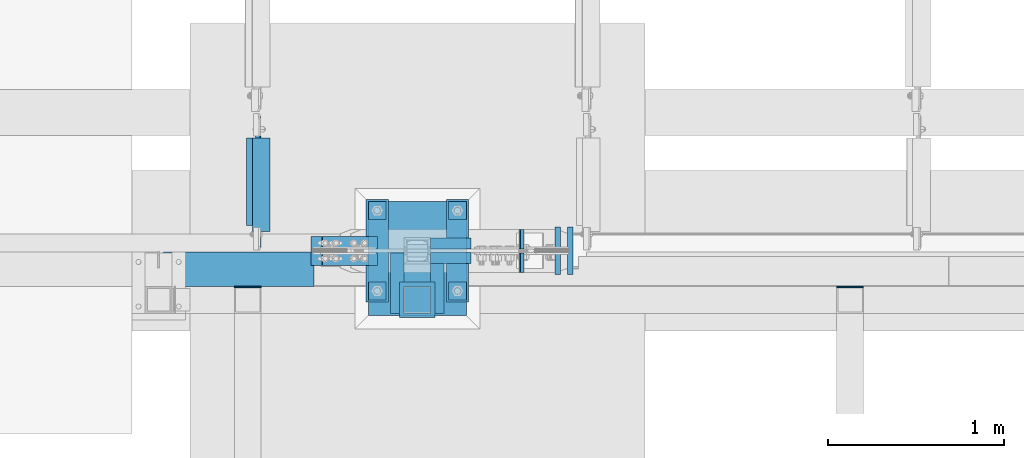
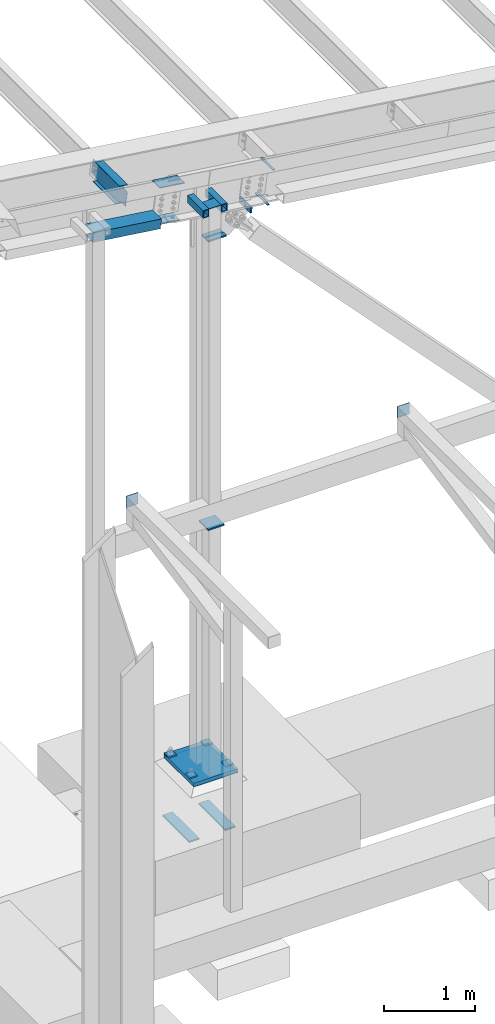
# One storey, part 848 of 1179: 22 beams, 2 members, 11 elements without a shape of their own.
"""IFC2X3 building model written with IfcOpenShell, lengths in millimetres."""

from ifc_helpers import new_model, si_unit, frame, origin_with_axes, place, context, subcontext, project, spatial, faceted_brep, material, type_object, element, aggregate, save


model = new_model("IFC2X3")

# Units and contexts
model_context = context("Model", 3, precision=1e-05, world=origin_with_axes())
body_context = subcontext(model_context, "Body", "Model", "MODEL_VIEW")
ifc_project = project(units=[si_unit("LENGTHUNIT", "METRE", prefix="MILLI"), si_unit("AREAUNIT", "SQUARE_METRE"), si_unit("VOLUMEUNIT", "CUBIC_METRE"), si_unit("MASSUNIT", "GRAM", prefix="KILO"), si_unit("TIMEUNIT", "SECOND"), si_unit("PLANEANGLEUNIT", "RADIAN"), si_unit("SOLIDANGLEUNIT", "STERADIAN"), si_unit("THERMODYNAMICTEMPERATUREUNIT", "DEGREE_CELSIUS"), si_unit("LUMINOUSINTENSITYUNIT", "LUMEN")], contexts=[model_context])

# Site, building, storey
site_placement = place(None, origin_with_axes())
site = spatial("IfcSite", under=ifc_project, at=site_placement, CompositionType="ELEMENT")
building_placement = place(site_placement, origin_with_axes())
building = spatial("IfcBuilding", under=site, at=building_placement, Name="Undefined", CompositionType="ELEMENT")
storey_placement = place(building_placement, origin_with_axes())
storey = spatial("IfcBuildingStorey", under=building, at=storey_placement, Name="Undefined", CompositionType="ELEMENT", Elevation=0.0)

# Assembly, beam
assembly_1_placement = place(storey_placement, origin_with_axes())
assembly_1 = element("IfcElementAssembly", 1, at=assembly_1_placement, inside=storey, Name="BEAM", AssemblyPlace="NOTDEFINED", PredefinedType="RIGID_FRAME")
ifc_material_1 = material(Name="STEEL/A992")
beam_type_1 = type_object("IfcBeamType", Name="W10X12", PredefinedType="NOTDEFINED")
beam_1_placement = place(assembly_1_placement, frame((26856.4181490507, 4648.2, 7565.95174486026), z_axis=(0.133813223953133, 0.0, 0.991006569652931), x_axis=(0.0, 1.0, 0.0)))
beam_1 = element("IfcBeam", 2, at=beam_1_placement, type_object=beam_type_1, material=ifc_material_1, Name="BEAM", ObjectType="W10X12", context=body_context, shape_type="Brep", body=[
    faceted_brep([(641.349999999998, -2.38124999986758, -120.650000000041), (641.349999999998, -50.7999999998792, -120.650000000054), (641.349999999998, -50.7999999998719, -125.412500000057), (641.349999999998, 50.8000000001484, -125.412500000028), (641.349999999998, 50.8000000001412, -120.650000000027), (641.349999999998, 2.38125000012951, -120.650000000038), (641.349999999998, 2.38125000012224, -106.362499801333), (641.349999999998, -2.38124999988213, -106.362499801329), (642.316729922585, 2.38125000011496, -101.502420283283), (642.316729922585, -2.38124999988213, -101.502420283279), (645.069743823064, 2.38125000011496, -97.3822438151255), (645.069743823064, -2.38124999988941, -97.3822438151219), (649.189920291217, 2.38125000010768, -94.6292299146444), (649.189920291217, -2.38124999989668, -94.6292299146407), (654.049999809263, 2.38125000010768, -93.6624999920532), (654.049999809263, -2.38124999989668, -93.6624999920496), (768.349999999998, -2.38124999988941, -93.6624999919513), (768.349999999998, 2.38125000010768, -93.6624999919441), (109.537500000001, 2.38124999985303, 120.650000000041), (109.537500000001, 50.7999999998647, 120.650000000056), (642.937499999997, 50.7999999998647, 120.650000000056), (642.937499999997, 2.38124999985303, 120.650000000041), (144.462500000001, -2.38124999988213, -106.362499807816), (144.462500000001, 2.38125000011496, -106.362499807819), (144.462500000001, 2.38125000012951, -120.650000000038), (144.462500000001, 50.8000000001412, -120.650000000027), (144.462500000001, 50.8000000001484, -125.412500000028), (144.462500000001, -50.7999999998719, -125.412500000057), (144.462500000001, -50.7999999998792, -120.650000000054), (144.462500000001, -2.38124999986758, -120.650000000041), (143.495770077414, -2.38124999988213, -101.502420289766), (143.495770077414, 2.38125000011496, -101.502420289768), (140.742756176935, -2.38124999988941, -97.3822438216066), (140.742756176935, 2.38125000011496, -97.3822438216102), (136.622579708782, -2.38124999989668, -94.6292299211254), (136.622579708782, 2.38125000010768, -94.6292299211291), (131.762500190736, -2.38124999988941, -93.6624999985379), (131.762500190736, 2.38125000010768, -93.6624999985397), (17.4624999999996, -2.38124999988941, -93.662499998647), (17.4624999999996, 2.38125000010768, -93.6624999986416), (17.4624999999996, -2.38125000011496, 93.6625000015429), (17.4624999999996, 2.38124999988941, 93.6625000015483), (96.8375001907361, -2.38125000011496, 93.662500001652), (96.8375001907361, 2.38124999988941, 93.6625000016502), (101.697579708782, -2.38125000011496, 94.6292299242414), (101.697579708782, 2.38124999987485, 94.6292299242377), (105.817756176935, -2.38125000011496, 97.3822438247225), (105.817756176935, 2.38124999988213, 97.3822438247189), (108.570770077414, -2.38125000012224, 101.50242029288), (108.570770077414, 2.38124999987485, 101.502420292876), (109.537500000001, -2.38125000012951, 106.36249981093), (109.537500000001, 2.38124999986758, 106.362499810928), (109.537500000001, -50.800000000163, 125.412500000028), (109.537500000001, 50.7999999998574, 125.412500000059), (109.537500000001, -2.38125000014406, 120.650000000041), (109.537500000001, -50.8000000001557, 120.650000000027), (642.937499999997, -2.38125000014406, 120.650000000041), (642.937499999997, -50.8000000001557, 120.650000000027), (642.937499999997, -50.800000000163, 125.412500000028), (642.937499999997, 50.7999999998574, 125.412500000059), (642.937499999997, -2.38125000012224, 100.012499817411), (642.937499999997, 2.38124999987485, 100.012499817409), (643.904229922585, -2.38125000012224, 95.1524202993623), (643.904229922585, 2.38124999988213, 95.1524202993587), (646.657243823063, -2.38125000011496, 91.0322438312032), (646.657243823063, 2.38124999988941, 91.0322438311996), (650.777420291217, -2.38125000010768, 88.2792299307239), (650.777420291217, 2.38124999988941, 88.2792299307202), (655.637499809262, -2.38125000010768, 87.3125000081345), (655.637499809262, 2.38124999988941, 87.3125000081309), (768.349999999998, -2.38125000010768, 87.3125000082346), (768.349999999998, 2.38124999988941, 87.31250000824)], [[[0, 1, 2, 3, 4, 5, 6, 7]], [[7, 6, 8, 9]], [[9, 8, 10, 11]], [[11, 10, 12, 13]], [[13, 12, 14, 15]], [[16, 15, 14, 17]], [[18, 19, 20, 21]], [[22, 23, 24, 25, 26, 27, 28, 29]], [[30, 31, 23, 22]], [[32, 33, 31, 30]], [[34, 35, 33, 32]], [[36, 37, 35, 34]], [[38, 39, 37, 36]], [[40, 41, 39, 38]], [[42, 43, 41, 40]], [[44, 45, 43, 42]], [[46, 47, 45, 44]], [[48, 49, 47, 46]], [[50, 51, 49, 48]], [[52, 53, 19, 18, 51, 50, 54, 55]], [[55, 54, 56, 57]], [[52, 55, 57, 58]], [[53, 52, 58, 59]], [[19, 53, 59, 20]], [[58, 57, 56, 60, 61, 21, 20, 59]], [[62, 63, 61, 60]], [[64, 65, 63, 62]], [[66, 67, 65, 64]], [[68, 69, 67, 66]], [[70, 71, 69, 68]], [[71, 70, 16, 17]], [[12, 10, 8, 6, 5, 24, 23, 31, 33, 35, 37, 39, 41, 43, 45, 47, 49, 51, 18, 21, 61, 63, 65, 67, 69, 71, 17, 14]], [[25, 24, 5, 4]], [[26, 25, 4, 3]], [[27, 26, 3, 2]], [[28, 27, 2, 1]], [[29, 28, 1, 0]], [[70, 68, 66, 64, 62, 60, 56, 54, 50, 48, 46, 44, 42, 40, 38, 36, 34, 32, 30, 22, 29, 0, 7, 9, 11, 13, 15, 16]]]),
])
aggregate(assembly_1, [beam_1])

assembly_2_placement = place(storey_placement, origin_with_axes())
assembly_2 = element("IfcElementAssembly", 3, at=assembly_2_placement, inside=storey, Name="COLUMN", AssemblyPlace="NOTDEFINED", PredefinedType="RIGID_FRAME")
ifc_material_2 = material(Name="STEEL/A36")
beam_type_2 = type_object("IfcBeamType", PredefinedType="NOTDEFINED")
beam_2_placement = place(assembly_2_placement, frame((27762.2, 4292.6, 7370.69880466022), z_axis=(1.0, 0.0, 0.0), x_axis=(0.0, 1.0, 0.0)))
beam_2 = element("IfcBeam", 4, at=beam_2_placement, type_object=beam_type_2, material=ifc_material_2, Name="PLATE", context=body_context, shape_type="Brep", body=[
    faceted_brep([(-1.47792889038101e-12, 3.17500000000018, -76.1999999999953), (1.36424205265939e-12, 3.17500000000018, 76.1999999999953), (152.399999999989, 3.17500000000018, 76.200000000028), (152.399999999986, 3.17500000000018, -76.1999999999625), (1.36424205265939e-12, -3.17500000000018, 76.1999999999953), (152.399999999989, -3.17500000000018, 76.200000000028), (-1.47792889038101e-12, -3.17500000000018, -76.1999999999953), (152.399999999986, -3.17500000000018, -76.1999999999625)], [[[0, 1, 2, 3]], [[1, 4, 5, 2]], [[4, 6, 7, 5]], [[6, 0, 3, 7]], [[5, 7, 3, 2]], [[6, 4, 1, 0]]]),
])

assembly_3_placement = place(storey_placement, origin_with_axes())
assembly_3 = element("IfcElementAssembly", 5, at=assembly_3_placement, inside=storey, Name="BEAM", AssemblyPlace="NOTDEFINED", PredefinedType="RIGID_FRAME")
beam_3_placement = place(assembly_3_placement, frame((30302.2, 4441.825, 3702.05), z_axis=(0.0, 0.0, -1.0), x_axis=(-1.0, 0.0, 0.0)))
beam_3 = element("IfcBeam", 6, at=beam_3_placement, type_object=beam_type_2, material=ifc_material_2, Name="PLATE", context=body_context, shape_type="Brep", body=[
    faceted_brep([(-1.47792889038101e-12, 3.17500000000018, -76.1999999999953), (1.36424205265939e-12, 3.17500000000018, 76.1999999999953), (152.399999999989, 3.17500000000018, 76.200000000028), (152.399999999986, 3.17500000000018, -76.1999999999625), (1.36424205265939e-12, -3.17500000000018, 76.1999999999953), (152.399999999989, -3.17500000000018, 76.200000000028), (-1.47792889038101e-12, -3.17500000000018, -76.1999999999953), (152.399999999986, -3.17500000000018, -76.1999999999625)], [[[0, 1, 2, 3]], [[1, 4, 5, 2]], [[4, 6, 7, 5]], [[6, 0, 3, 7]], [[5, 7, 3, 2]], [[6, 4, 1, 0]]]),
])
aggregate(assembly_3, [beam_3])

assembly_4_placement = place(storey_placement, origin_with_axes())
assembly_4 = element("IfcElementAssembly", 7, at=assembly_4_placement, inside=storey, Name="BEAM", AssemblyPlace="NOTDEFINED", PredefinedType="RIGID_FRAME")
beam_4_placement = place(assembly_4_placement, frame((26873.2, 4441.825, 3702.05), z_axis=(0.0, 0.0, -1.0), x_axis=(-1.0, 0.0, 0.0)))
beam_4 = element("IfcBeam", 8, at=beam_4_placement, type_object=beam_type_2, material=ifc_material_2, Name="PLATE", context=body_context, shape_type="Brep", body=[
    faceted_brep([(-1.47792889038101e-12, 3.17500000000018, -76.1999999999953), (1.36424205265939e-12, 3.17500000000018, 76.1999999999953), (152.399999999989, 3.17500000000018, 76.200000000028), (152.399999999986, 3.17500000000018, -76.1999999999625), (1.36424205265939e-12, -3.17500000000018, 76.1999999999953), (152.399999999989, -3.17500000000018, 76.200000000028), (-1.47792889038101e-12, -3.17500000000018, -76.1999999999953), (152.399999999986, -3.17500000000018, -76.1999999999625)], [[[0, 1, 2, 3]], [[1, 4, 5, 2]], [[4, 6, 7, 5]], [[6, 0, 3, 7]], [[5, 7, 3, 2]], [[6, 4, 1, 0]]]),
])
aggregate(assembly_4, [beam_4])

# Assembly, beams
assembly_5_placement = place(storey_placement, origin_with_axes())
assembly_5 = element("IfcElementAssembly", 9, at=assembly_5_placement, inside=storey, Name="BEAM", AssemblyPlace="NOTDEFINED", PredefinedType="RIGID_FRAME")
ifc_material_3 = material(Name="STEEL/A572-GR.50")
beam_type_3 = type_object("IfcBeamType", PredefinedType="NOTDEFINED")
beam_5_placement = place(assembly_5_placement, frame((28546.3739735034, 4648.2000010376, 6988.54544430494), z_axis=(0.0, -1.0, 0.0), x_axis=(0.99100656965293, 0.0, -0.133813223953134)))
beam_5 = element("IfcBeam", 10, at=beam_5_placement, type_object=beam_type_3, material=ifc_material_3, Name="PLATE", context=body_context, shape_type="Brep", body=[
    faceted_brep([(7.27595761418343e-12, 4.76250000000437, -134.9375), (7.27595761418343e-12, 4.76250000000437, 134.9375), (31.7500000000182, 4.76249999999527, 134.9375), (31.7500000000182, 4.76249999999527, -134.9375), (-3.63797880709171e-12, -4.76249999999891, 134.9375), (31.7500000000073, -4.762500000008, 134.9375), (-3.63797880709171e-12, -4.76249999999891, -134.9375), (31.7500000000073, -4.762500000008, -134.9375)], [[[0, 1, 2, 3]], [[1, 4, 5, 2]], [[4, 6, 7, 5]], [[6, 0, 3, 7]], [[5, 7, 3, 2]], [[6, 4, 1, 0]]]),
])
beam_6_placement = place(assembly_5_placement, frame((28617.2378463457, 4648.2000010376, 7430.31393517149), z_axis=(0.0, -1.0, 0.0), x_axis=(0.99100656965293, 0.0, -0.133813223953134)))
beam_6 = element("IfcBeam", 11, at=beam_6_placement, type_object=beam_type_3, material=ifc_material_3, Name="PLATE", context=body_context, shape_type="Brep", body=[
    faceted_brep([(7.27595761418343e-12, 4.76250000000437, -134.9375), (7.27595761418343e-12, 4.76250000000437, 134.9375), (31.7500000000182, 4.76249999999527, 134.9375), (31.7500000000182, 4.76249999999527, -134.9375), (-3.63797880709171e-12, -4.76249999999891, 134.9375), (31.7500000000073, -4.762500000008, 134.9375), (-3.63797880709171e-12, -4.76249999999891, -134.9375), (31.7500000000073, -4.762500000008, -134.9375)], [[[0, 1, 2, 3]], [[1, 4, 5, 2]], [[4, 6, 7, 5]], [[6, 0, 3, 7]], [[5, 7, 3, 2]], [[6, 4, 1, 0]]]),
])
aggregate(assembly_5, [beam_5, beam_6])

assembly_6_placement = place(storey_placement, origin_with_axes())
assembly_6 = element("IfcElementAssembly", 12, at=assembly_6_placement, inside=storey, Name="TEMPLATE", AssemblyPlace="NOTDEFINED", PredefinedType="RIGID_FRAME")
beam_type_4 = type_object("IfcBeamType", PredefinedType="NOTDEFINED")
beam_7_placement = place(assembly_6_placement, frame((27990.8000061035, 4356.1, -1057.275), z_axis=(-1.0, 0.0, 0.0), x_axis=(0.0, 1.0, 0.0)))
beam_7 = element("IfcBeam", 13, at=beam_7_placement, type_object=beam_type_4, material=ifc_material_2, Name="SQ WASHER", context=body_context, shape_type="Brep", body=[
    faceted_brep([(0.0, 9.52500000000146, -63.5), (0.0, 9.52500000000146, 63.5), (584.199999999997, 9.52500000000009, 63.5), (584.199999999997, 9.52500000000009, -63.5), (0.0, -9.52500000000146, 63.5), (584.199999999997, -9.52500000000009, 63.5), (0.0, -9.52500000000146, -63.5), (584.199999999997, -9.52500000000009, -63.5)], [[[0, 1, 2, 3]], [[1, 4, 5, 2]], [[4, 6, 7, 5]], [[6, 0, 3, 7]], [[5, 7, 3, 2]], [[6, 4, 1, 0]]]),
])
beam_8_placement = place(assembly_6_placement, frame((27533.5999938965, 4940.3, -1057.275), z_axis=(1.0, 0.0, 0.0), x_axis=(0.0, -1.0, 0.0)))
beam_8 = element("IfcBeam", 14, at=beam_8_placement, type_object=beam_type_4, material=ifc_material_2, Name="SQ WASHER", context=body_context, shape_type="Brep", body=[
    faceted_brep([(0.0, 9.52500000000146, -63.5), (0.0, 9.52500000000146, 63.5), (584.199999999997, 9.52500000000009, 63.5), (584.199999999997, 9.52500000000009, -63.5), (0.0, -9.52500000000146, 63.5), (584.199999999997, -9.52500000000009, 63.5), (0.0, -9.52500000000146, -63.5), (584.199999999997, -9.52500000000009, -63.5)], [[[0, 1, 2, 3]], [[1, 4, 5, 2]], [[4, 6, 7, 5]], [[6, 0, 3, 7]], [[5, 7, 3, 2]], [[6, 4, 1, 0]]]),
])

# Assembly, beam
assembly_7_placement = place(storey_placement, origin_with_axes())
assembly_7 = element("IfcElementAssembly", 15, at=assembly_7_placement, inside=storey, Name="COLUMN", AssemblyPlace="NOTDEFINED", PredefinedType="RIGID_FRAME")
beam_type_5 = type_object("IfcBeamType", PredefinedType="NOTDEFINED")
beam_9_placement = place(assembly_7_placement, frame((27762.2, 4267.2, 3101.975), z_axis=(1.0, 0.0, 0.0), x_axis=(0.0, 1.0, 0.0)))
beam_9 = element("IfcBeam", 16, at=beam_9_placement, type_object=beam_type_5, material=ifc_material_2, Name="PLATE", context=body_context, shape_type="Brep", body=[
    faceted_brep([(0.0, 9.52500000000009, -101.599999999999), (0.0, 9.52500000000009, 101.599999999999), (203.199999999999, 9.52500000000009, 101.599999999999), (203.199999999999, 9.52500000000009, -101.599999999999), (0.0, -9.52500000000009, 101.599999999999), (203.199999999999, -9.52500000000009, 101.599999999999), (0.0, -9.52500000000009, -101.599999999999), (203.199999999999, -9.52500000000009, -101.599999999999)], [[[0, 1, 2, 3]], [[1, 4, 5, 2]], [[4, 6, 7, 5]], [[6, 0, 3, 7]], [[5, 7, 3, 2]], [[6, 4, 1, 0]]]),
])
aggregate(assembly_7, [beam_9])

# Beam
ifc_material_4 = material()
beam_type_6 = type_object("IfcBeamType", Name="HSS4X3X5/16", PredefinedType="NOTDEFINED")
beam_10_placement = place(assembly_2_placement, frame((27876.5, 4292.6, 7323.07380466022), z_axis=(0.0, 0.0, 1.0), x_axis=(0.0, 1.0, 0.0)))
beam_10 = element("IfcBeam", 17, at=beam_10_placement, type_object=beam_type_6, material=ifc_material_4, Name="BEAM", ObjectType="HSS4X3X5/16", context=body_context, shape_type="Brep", body=[
    faceted_brep([(0.0, 30.1624999999985, -42.8625000000002), (0.0, -30.1624999999985, -42.8625000000002), (344.487500000005, -30.1624999999985, -42.8625000000002), (344.487500000005, 30.1624999999985, -42.8625000000002), (0.0, -30.1624999999985, 42.8625000000002), (344.487500000005, -30.1624999999985, 42.8625000000002), (0.0, 30.1624999999985, 42.8625000000002), (344.487500000005, 30.1624999999985, 42.8625000000002), (0.0, 38.0999999999985, -50.8000000000002), (1.45519152283669e-11, 38.1000000000004, 50.8000000000002), (344.487500000005, 38.0999999999985, 50.8000000000002), (344.487500000005, 38.0999999999985, -50.8000000000002), (0.0, -38.0999999999985, 50.8000000000002), (344.487500000005, -38.0999999999985, 50.8000000000002), (0.0, -38.0999999999985, -50.8000000000002), (344.487500000005, -38.0999999999985, -50.8000000000002)], [[[0, 1, 2, 3]], [[1, 4, 5, 2]], [[4, 6, 7, 5]], [[6, 0, 3, 7]], [[8, 9, 10, 11]], [[9, 12, 13, 10]], [[12, 14, 15, 13]], [[14, 8, 11, 15]], [[13, 15, 11, 10], [5, 7, 3, 2]], [[14, 12, 9, 8], [6, 4, 1, 0]]]),
])

beam_11_placement = place(assembly_2_placement, frame((27647.9, 4292.6, 7323.07380466022), z_axis=(0.0, 0.0, 1.0), x_axis=(0.0, 1.0, 0.0)))
beam_11 = element("IfcBeam", 18, at=beam_11_placement, type_object=beam_type_6, material=ifc_material_4, Name="BEAM", ObjectType="HSS4X3X5/16", context=body_context, shape_type="Brep", body=[
    faceted_brep([(0.0, 30.1624999999985, -42.8625000000002), (0.0, -30.1624999999985, -42.8625000000002), (344.487500000005, -30.1624999999985, -42.8625000000002), (344.487500000005, 30.1624999999985, -42.8625000000002), (0.0, -30.1624999999985, 42.8625000000002), (344.487500000005, -30.1624999999985, 42.8625000000002), (0.0, 30.1624999999985, 42.8625000000002), (344.487500000005, 30.1624999999985, 42.8625000000002), (0.0, 38.0999999999985, -50.8000000000002), (1.45519152283669e-11, 38.1000000000004, 50.8000000000002), (344.487500000005, 38.0999999999985, 50.8000000000002), (344.487500000005, 38.0999999999985, -50.8000000000002), (0.0, -38.0999999999985, 50.8000000000002), (344.487500000005, -38.0999999999985, 50.8000000000002), (0.0, -38.0999999999985, -50.8000000000002), (344.487500000005, -38.0999999999985, -50.8000000000002)], [[[0, 1, 2, 3]], [[1, 4, 5, 2]], [[4, 6, 7, 5]], [[6, 0, 3, 7]], [[8, 9, 10, 11]], [[9, 12, 13, 10]], [[12, 14, 15, 13]], [[14, 8, 11, 15]], [[13, 15, 11, 10], [5, 7, 3, 2]], [[14, 12, 9, 8], [6, 4, 1, 0]]]),
])

aggregate(assembly_2, [beam_10, beam_11, beam_2])

# Assembly, beam
assembly_8_placement = place(storey_placement, origin_with_axes())
assembly_8 = element("IfcElementAssembly", 19, at=assembly_8_placement, inside=storey, Name="BEAM", AssemblyPlace="NOTDEFINED", PredefinedType="RIGID_FRAME")
beam_type_7 = type_object("IfcBeamType", PredefinedType="NOTDEFINED")
beam_12_placement = place(assembly_8_placement, frame((26744.5414509503, 4642.64374999961, 7380.81985577198), z_axis=(-0.99100656978554, 0.0, 0.133813222971043), x_axis=(0.0, -1.0, 0.0)))
beam_12 = element("IfcBeam", 20, at=beam_12_placement, type_object=beam_type_7, material=ifc_material_2, Name="BENT_PLATE", context=body_context, shape_type="Brep", body=[
    faceted_brep([(5.18411980010569e-11, -3.17500000011933, -431.800000000097), (-7.73070496506989e-11, -3.17499999988104, 431.800000000094), (-5.18411980010569e-11, 3.17500000012114, 431.800000000087), (7.73070496506989e-11, 3.17499999988286, -431.800000000105), (197.64375000052, 3.17499999934626, 431.800000000112), (197.643750001026, 3.17499999910797, -431.800000000076), (191.293750001027, -3.17500000086875, -431.800000000065), (191.29375000052, -3.17500000063046, 431.800000000123), (197.643750000724, -123.825000002931, 431.800000000319), (197.643750000822, -123.825000003768, -431.799999999872), (191.293750000822, -117.475000003766, -431.799999999883), (191.293750000724, -117.475000002929, 431.800000000309), (27.7812499992751, -123.825000003033, 431.800000000341), (27.7812499991533, -123.825000003664, -431.79999999985), (27.7812499992751, -117.475000003031, 431.80000000033), (27.7812499991533, -117.475000003662, -431.799999999857)], [[[0, 1, 2, 3]], [[3, 2, 4, 5]], [[1, 0, 6, 7]], [[5, 4, 8, 9]], [[7, 6, 10, 11]], [[9, 8, 12, 13]], [[8, 4, 2, 1, 7, 11, 14, 12]], [[11, 10, 15, 14]], [[10, 6, 0, 3, 5, 9, 13, 15]], [[14, 15, 13, 12]]]),
])
aggregate(assembly_8, [beam_12])

assembly_9_placement = place(storey_placement, origin_with_axes())
assembly_9 = element("IfcElementAssembly", 21, at=assembly_9_placement, inside=storey, Name="PLATE", AssemblyPlace="NOTDEFINED", PredefinedType="RIGID_FRAME")
beam_type_8 = type_object("IfcBeamType", PredefinedType="NOTDEFINED")
beam_13_placement = place(assembly_9_placement, frame((27838.4, 4689.475, 6709.62229362541), z_axis=(0.0, -1.0, 0.0), x_axis=(1.0, 0.0, 0.0)))
beam_13 = element("IfcBeam", 22, at=beam_13_placement, type_object=beam_type_8, material=ifc_material_3, Name="PLATE", context=body_context, shape_type="Brep", body=[
    faceted_brep([(0.0, 9.52499999999964, -31.75), (0.0, 9.52499999999964, 31.75), (230.614175395127, 9.52499999999964, 31.75), (230.614175395127, 9.52499999999964, -31.75), (0.0, -9.52499999999964, 31.75), (230.614175395127, -9.52499999999964, 31.75), (0.0, -9.52499999999964, -31.75), (230.614175395127, -9.52499999999964, -31.75)], [[[0, 1, 2, 3]], [[1, 4, 5, 2]], [[4, 6, 7, 5]], [[6, 0, 3, 7]], [[5, 7, 3, 2]], [[6, 4, 1, 0]]]),
])
aggregate(assembly_9, [beam_13])

assembly_10_placement = place(storey_placement, origin_with_axes())
assembly_10 = element("IfcElementAssembly", 23, at=assembly_10_placement, inside=storey, Name="PLATE", AssemblyPlace="NOTDEFINED", PredefinedType="RIGID_FRAME")
beam_14_placement = place(assembly_10_placement, frame((27838.4, 4606.925, 6709.62229362541), z_axis=(0.0, -1.0, 0.0), x_axis=(1.0, 0.0, 0.0)))
beam_14 = element("IfcBeam", 24, at=beam_14_placement, type_object=beam_type_8, material=ifc_material_3, Name="PLATE", context=body_context, shape_type="Brep", body=[
    faceted_brep([(0.0, 9.52499999999964, -31.75), (0.0, 9.52499999999964, 31.75), (230.614175395127, 9.52499999999964, 31.75), (230.614175395127, 9.52499999999964, -31.75), (0.0, -9.52499999999964, 31.75), (230.614175395127, -9.52499999999964, 31.75), (0.0, -9.52499999999964, -31.75), (230.614175395127, -9.52499999999964, -31.75)], [[[0, 1, 2, 3]], [[1, 4, 5, 2]], [[4, 6, 7, 5]], [[6, 0, 3, 7]], [[5, 7, 3, 2]], [[6, 4, 1, 0]]]),
])
aggregate(assembly_10, [beam_14])

# Assembly, members, beams
assembly_11_placement = place(storey_placement, origin_with_axes())
assembly_11 = element("IfcElementAssembly", 25, at=assembly_11_placement, inside=storey, Name="COLUMN", AssemblyPlace="NOTDEFINED", PredefinedType="RIGID_FRAME")
member_type = type_object("IfcMemberType", PredefinedType="NOTDEFINED")
member_1_placement = place(assembly_11_placement, frame((28349.6007638856, 4581.5250010376, 6943.02945700906), z_axis=(0.0, -1.0, 0.0), x_axis=(0.133813223953133, 0.0, 0.991006569652931)))
member_1 = element("IfcMember", 26, at=member_1_placement, type_object=member_type, material=ifc_material_3, Name="PLATE", context=body_context, shape_type="Brep", body=[
    faceted_brep([(0.0, 9.52500000000509, -55.5625), (0.0, 9.52500000000509, 55.5625), (76.2000000000407, 9.52499999991778, 55.5625), (76.2000000000407, 9.52499999991778, -55.5625), (-5.45696821063757e-12, -9.52500000000146, 55.5625), (76.2000000000371, -9.52500000008877, 55.5625), (-5.45696821063757e-12, -9.52500000000146, -55.5625), (76.2000000000371, -9.52500000008877, -55.5625)], [[[0, 1, 2, 3]], [[1, 4, 5, 2]], [[4, 6, 7, 5]], [[6, 0, 3, 7]], [[5, 7, 3, 2]], [[6, 4, 1, 0]]]),
])
member_2_placement = place(assembly_11_placement, frame((28349.6007638856, 4714.8750010376, 6943.02945700906), z_axis=(0.0, -1.0, 0.0), x_axis=(0.133813223953133, 0.0, 0.991006569652931)))
member_2 = element("IfcMember", 27, at=member_2_placement, type_object=member_type, material=ifc_material_3, Name="PLATE", context=body_context, shape_type="Brep", body=[
    faceted_brep([(0.0, 9.52500000000509, -55.5625), (0.0, 9.52500000000509, 55.5625), (76.2000000000407, 9.52499999991778, 55.5625), (76.2000000000407, 9.52499999991778, -55.5625), (-5.45696821063757e-12, -9.52500000000146, 55.5625), (76.2000000000371, -9.52500000008877, 55.5625), (-5.45696821063757e-12, -9.52500000000146, -55.5625), (76.2000000000371, -9.52500000008877, -55.5625)], [[[0, 1, 2, 3]], [[1, 4, 5, 2]], [[4, 6, 7, 5]], [[6, 0, 3, 7]], [[5, 7, 3, 2]], [[6, 4, 1, 0]]]),
])
beam_type_9 = type_object("IfcBeamType", PredefinedType="NOTDEFINED")
beam_15_placement = place(assembly_11_placement, frame((27157.027738153, 4648.2000010376, 7174.58480344213), z_axis=(0.0, -1.0, 0.0), x_axis=(0.99100656965293, 0.0, -0.133813223953134)))
beam_15 = element("IfcBeam", 28, at=beam_15_placement, type_object=beam_type_9, material=ifc_material_3, Name="PLATE", context=body_context, shape_type="Brep", body=[
    faceted_brep([(1.09139364212751e-11, 6.35000000000218, -82.5500000000002), (1.09139364212751e-11, 6.35000000000218, 82.5500000000002), (317.500035216472, 6.34999999991487, 82.5500000000002), (317.500035216472, 6.34999999991487, -82.5500000000002), (-7.27595761418343e-12, -6.35000000000218, 82.5500000000002), (317.500035216453, -6.35000000008949, 82.5500000000002), (-7.27595761418343e-12, -6.35000000000218, -82.5500000000002), (317.500035216453, -6.35000000008949, -82.5500000000002)], [[[0, 1, 2, 3]], [[1, 4, 5, 2]], [[4, 6, 7, 5]], [[6, 0, 3, 7]], [[5, 7, 3, 2]], [[6, 4, 1, 0]]]),
])
beam_16_placement = place(assembly_11_placement, frame((27221.1756812518, 4648.2000010376, 7649.65766689436), z_axis=(0.0, -1.0, 0.0), x_axis=(0.99100656965293, 0.0, -0.133813223953134)))
beam_16 = element("IfcBeam", 29, at=beam_16_placement, type_object=beam_type_9, material=ifc_material_3, Name="PLATE", context=body_context, shape_type="Brep", body=[
    faceted_brep([(317.500035216453, -6.35000000008949, -11.1124989760165), (317.500035216472, 6.34999999991487, -11.1124989750033), (161.925043380263, 6.34999999995671, -11.112500219464), (161.925043380241, -6.35000000004584, -11.112500220469), (158.279984353438, 6.34999999996035, -10.3874530428175), (158.279984353412, -6.35000000004584, -10.3874530438216), (155.189852342461, 6.34999999995853, -8.32269328145048), (155.189852342435, -6.35000000004402, -8.32269328245548), (153.125091792452, 6.34999999996035, -5.23256179743021), (153.12509179243, -6.35000000004402, -5.2325617984352), (152.400043685542, 6.34999999996035, -1.58750295564641), (152.400043685517, -6.35000000004402, -1.58750295665141), (152.400042900641, 6.34999999996035, 1.58749780728249), (152.400042900612, -6.35000000004402, 1.58749780627841), (153.125089641315, 6.34999999996035, 5.2325580600891), (153.125089641286, -6.35000000004402, 5.23255805908411), (155.189849838654, 6.34999999996035, 8.32269112360245), (155.189849838633, -6.35000000004402, 8.32269112259746), (158.279982375218, 6.34999999995853, 10.3874521095877), (158.279982375192, -6.35000000004584, 10.3874521085827), (161.925042442988, 6.34999999995853, 11.1124997805255), (161.925042442959, -6.35000000004766, 11.1124997795205), (317.500035216453, -6.35000000008949, 11.1125010238829), (317.500035216472, 6.34999999991487, 11.1125010248961), (-7.27595761418343e-12, -6.35000000000218, -82.5500000000002), (1.09139364212751e-11, 6.35000000000218, -82.5500000000002), (317.500035216472, 6.34999999991487, -82.5500000000002), (317.500035216453, -6.35000000008949, -82.5500000000002), (-7.27595761418343e-12, -6.35000000000218, 82.5500000000002), (1.09139364212751e-11, 6.35000000000218, 82.5500000000002), (317.500035216453, -6.35000000008949, 82.5500000000002), (317.500035216472, 6.34999999991487, 82.5500000000002)], [[[0, 1, 2, 3]], [[3, 2, 4, 5]], [[5, 4, 6, 7]], [[7, 6, 8, 9]], [[9, 8, 10, 11]], [[11, 10, 12, 13]], [[13, 12, 14, 15]], [[15, 14, 16, 17]], [[17, 16, 18, 19]], [[19, 18, 20, 21]], [[22, 21, 20, 23]], [[24, 25, 26, 27]], [[24, 28, 29, 25]], [[29, 28, 30, 31]], [[31, 30, 22, 23]], [[18, 16, 14, 12, 10, 8, 6, 4, 2, 1, 26, 25, 29, 31, 23, 20]], [[27, 26, 1, 0]], [[30, 28, 24, 27, 0, 3, 5, 7, 9, 11, 13, 15, 17, 19, 21, 22]]]),
])

# Beam
beam_type_10 = type_object("IfcBeamType", PredefinedType="NOTDEFINED")
beam_17_placement = place(assembly_6_placement, frame((28041.6, 4876.80001220703, -220.6625), z_axis=(0.0, -1.0, 0.0), x_axis=(-1.0, 0.0, 0.0)))
beam_17 = element("IfcBeam", 30, at=beam_17_placement, type_object=beam_type_10, material=ifc_material_2, Name="SQ WASHER", context=body_context, shape_type="Brep", body=[
    faceted_brep([(0.0, 7.9375, -50.8000000000002), (0.0, 7.9375, 50.8000000000002), (101.598992919513, 7.9375, 50.8000000000002), (101.598992919513, 7.9375, -50.8000000000002), (0.0, -7.9375, 50.8000000000002), (101.598992919513, -7.9375, 50.8000000000002), (0.0, -7.9375, -50.8000000000002), (101.598992919513, -7.9375, -50.8000000000002)], [[[0, 1, 2, 3]], [[1, 4, 5, 2]], [[4, 6, 7, 5]], [[6, 0, 3, 7]], [[5, 7, 3, 2]], [[6, 4, 1, 0]]]),
])

beam_18_placement = place(assembly_6_placement, frame((28041.6, 4419.60001220703, -220.6625), z_axis=(0.0, -1.0, 0.0), x_axis=(-1.0, 0.0, 0.0)))
beam_18 = element("IfcBeam", 31, at=beam_18_placement, type_object=beam_type_10, material=ifc_material_2, Name="SQ WASHER", context=body_context, shape_type="Brep", body=[
    faceted_brep([(0.0, 7.9375, -50.8000000000002), (0.0, 7.9375, 50.8000000000002), (101.598992919513, 7.9375, 50.8000000000002), (101.598992919513, 7.9375, -50.8000000000002), (0.0, -7.9375, 50.8000000000002), (101.598992919513, -7.9375, 50.8000000000002), (0.0, -7.9375, -50.8000000000002), (101.598992919513, -7.9375, -50.8000000000002)], [[[0, 1, 2, 3]], [[1, 4, 5, 2]], [[4, 6, 7, 5]], [[6, 0, 3, 7]], [[5, 7, 3, 2]], [[6, 4, 1, 0]]]),
])

beam_19_placement = place(assembly_6_placement, frame((27584.4, 4876.8, -220.6625), z_axis=(0.0, -1.0, 0.0), x_axis=(-1.0, 0.0, 0.0)))
beam_19 = element("IfcBeam", 32, at=beam_19_placement, type_object=beam_type_10, material=ifc_material_2, Name="SQ WASHER", context=body_context, shape_type="Brep", body=[
    faceted_brep([(0.0, 7.9375, -50.8000000000002), (0.0, 7.9375, 50.8000000000002), (101.598992919513, 7.9375, 50.8000000000002), (101.598992919513, 7.9375, -50.8000000000002), (0.0, -7.9375, 50.8000000000002), (101.598992919513, -7.9375, 50.8000000000002), (0.0, -7.9375, -50.8000000000002), (101.598992919513, -7.9375, -50.8000000000002)], [[[0, 1, 2, 3]], [[1, 4, 5, 2]], [[4, 6, 7, 5]], [[6, 0, 3, 7]], [[5, 7, 3, 2]], [[6, 4, 1, 0]]]),
])

beam_20_placement = place(assembly_6_placement, frame((27584.4, 4419.6, -220.6625), z_axis=(0.0, -1.0, 0.0), x_axis=(-1.0, 0.0, 0.0)))
beam_20 = element("IfcBeam", 33, at=beam_20_placement, type_object=beam_type_10, material=ifc_material_2, Name="SQ WASHER", context=body_context, shape_type="Brep", body=[
    faceted_brep([(0.0, 7.9375, -50.8000000000002), (0.0, 7.9375, 50.8000000000002), (101.598992919513, 7.9375, 50.8000000000002), (101.598992919513, 7.9375, -50.8000000000002), (0.0, -7.9375, 50.8000000000002), (101.598992919513, -7.9375, 50.8000000000002), (0.0, -7.9375, -50.8000000000002), (101.598992919513, -7.9375, -50.8000000000002)], [[[0, 1, 2, 3]], [[1, 4, 5, 2]], [[4, 6, 7, 5]], [[6, 0, 3, 7]], [[5, 7, 3, 2]], [[6, 4, 1, 0]]]),
])

beam_type_11 = type_object("IfcBeamType", PredefinedType="NOTDEFINED")
beam_21_placement = place(assembly_11_placement, frame((27482.8, 4603.75, -254.0), z_axis=(0.0, 1.0, 0.0), x_axis=(1.0, 0.0, 0.0)))
beam_21 = element("IfcBeam", 34, at=beam_21_placement, type_object=beam_type_11, material=ifc_material_3, context=body_context, shape_type="Brep", body=[
    faceted_brep([(0.0, 25.4, -323.85), (0.0, 25.4, 323.85), (558.799999999981, 25.4, 323.85), (558.799999999981, 25.4, -323.85), (0.0, -25.4, 323.85), (558.799999999981, -25.4, 323.85), (0.0, -25.4, -323.85), (558.799999999981, -25.4, -323.85)], [[[0, 1, 2, 3]], [[1, 4, 5, 2]], [[4, 6, 7, 5]], [[6, 0, 3, 7]], [[5, 7, 3, 2]], [[6, 4, 1, 0]]]),
])

aggregate(assembly_11, [member_1, member_2, beam_15, beam_16, beam_21])

beam_type_12 = type_object("IfcBeamType", PredefinedType="NOTDEFINED")
beam_22_placement = place(assembly_6_placement, frame((27482.8, 4603.74999999964, -277.812499999999), z_axis=(0.0, 1.0, 0.0), x_axis=(1.0, 0.0, 0.0)))
beam_22 = element("IfcBeam", 35, at=beam_22_placement, type_object=beam_type_12, material=ifc_material_2, Name="TEMPLATE", context=body_context, shape_type="Brep", body=[
    faceted_brep([(0.0, 1.58749999999998, -323.85), (0.0, 1.58749999999998, 323.85), (558.799999999981, 1.58749999999998, 323.85), (558.799999999981, 1.58749999999998, -323.85), (0.0, -1.58749999999998, 323.85), (558.799999999981, -1.58749999999998, 323.85), (0.0, -1.58749999999998, -323.85), (558.799999999981, -1.58749999999998, -323.85)], [[[0, 1, 2, 3]], [[1, 4, 5, 2]], [[4, 6, 7, 5]], [[6, 0, 3, 7]], [[5, 7, 3, 2]], [[6, 4, 1, 0]]]),
])

aggregate(assembly_6, [beam_17, beam_18, beam_19, beam_20, beam_7, beam_8, beam_22])

save(model, "model.ifc")
